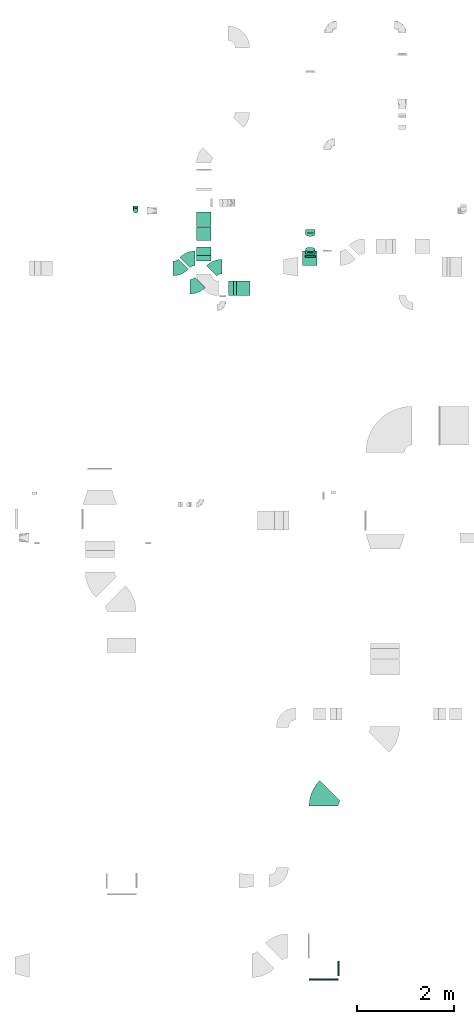
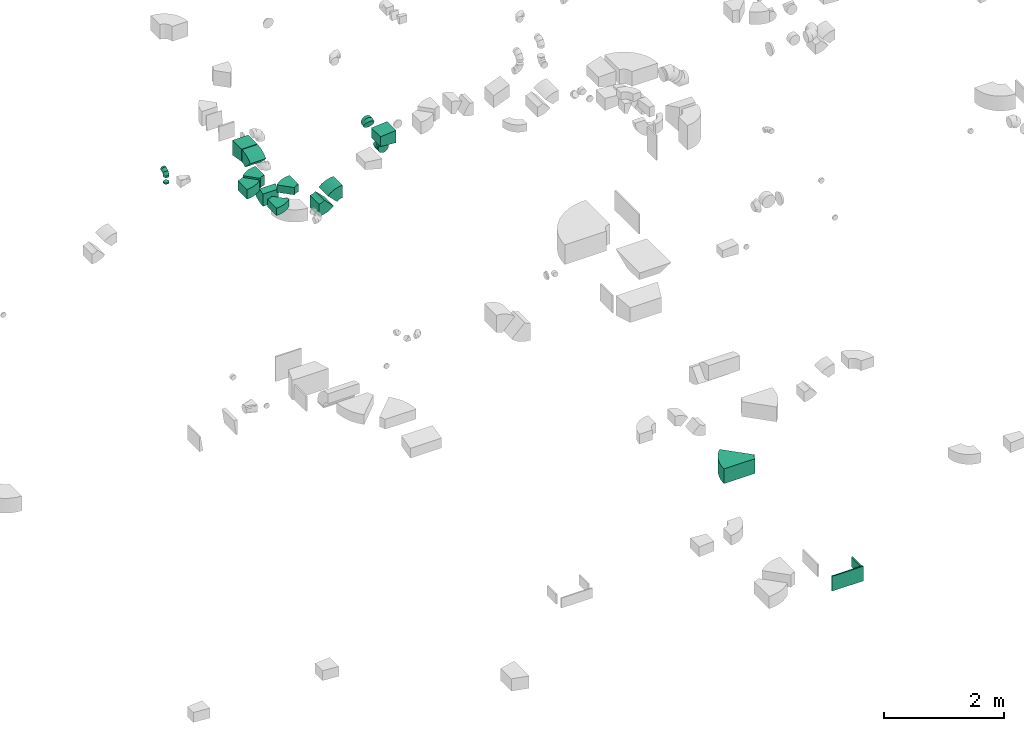
# One storey, part 23 of 44: 18 flow fittings.
"""IFC2X3 building model written with IfcOpenShell, lengths in millimetres."""

from ifc_helpers import new_model, entity, si_unit, converted_unit, derived_unit, direction, frame, frame_2d, origin, origin_2d_with_axis, place, context, subcontext, project, spatial, polyline, circle_curve, parameter, trimmed, segment, composite_curve, rectangle, outline, extrude, faceted_brep, source, transform, mapped, material, type_object, type_shapes, element, save


model = new_model("IFC2X3")

# Units and contexts
model_context = context("Model", 3, precision=0.01, world=origin(), true_north=direction((6.12303176911189e-17, 1.0)))
body_context = subcontext(model_context, "Body", "Model", "MODEL_VIEW")
ifc_project = project(units=[si_unit("LENGTHUNIT", "METRE", prefix="MILLI"), si_unit("AREAUNIT", "SQUARE_METRE"), si_unit("VOLUMEUNIT", "CUBIC_METRE"), converted_unit("PLANEANGLEUNIT", "DEGREE", entity("IfcRatioMeasure", 0.0174532925199433), si_unit("PLANEANGLEUNIT", "RADIAN"), dimensions=[0, 0, 0, 0, 0, 0, 0]), si_unit("MASSUNIT", "GRAM", prefix="KILO"), derived_unit("MASSDENSITYUNIT", [(si_unit("MASSUNIT", "GRAM", prefix="KILO"), 1), (si_unit("LENGTHUNIT", "METRE"), -3)]), derived_unit("MOMENTOFINERTIAUNIT", [(si_unit("LENGTHUNIT", "METRE"), 4)]), si_unit("TIMEUNIT", "SECOND"), si_unit("FREQUENCYUNIT", "HERTZ"), si_unit("THERMODYNAMICTEMPERATUREUNIT", "DEGREE_CELSIUS"), derived_unit("THERMALTRANSMITTANCEUNIT", [(si_unit("MASSUNIT", "GRAM", prefix="KILO"), 1), (si_unit("THERMODYNAMICTEMPERATUREUNIT", "KELVIN"), -1), (si_unit("TIMEUNIT", "SECOND"), -3)]), derived_unit("VOLUMETRICFLOWRATEUNIT", [(si_unit("LENGTHUNIT", "METRE"), 3), (si_unit("TIMEUNIT", "SECOND"), -1)]), derived_unit("MASSFLOWRATEUNIT", [(si_unit("MASSUNIT", "GRAM", prefix="KILO"), 1), (si_unit("TIMEUNIT", "SECOND"), -1)]), derived_unit("ROTATIONALFREQUENCYUNIT", [(si_unit("TIMEUNIT", "SECOND"), -1)]), si_unit("ELECTRICCURRENTUNIT", "AMPERE"), si_unit("ELECTRICVOLTAGEUNIT", "VOLT"), si_unit("POWERUNIT", "WATT"), si_unit("FORCEUNIT", "NEWTON", prefix="KILO"), si_unit("ILLUMINANCEUNIT", "LUX"), si_unit("LUMINOUSFLUXUNIT", "LUMEN"), si_unit("LUMINOUSINTENSITYUNIT", "CANDELA"), derived_unit("USERDEFINED", [(si_unit("MASSUNIT", "GRAM", prefix="KILO"), -1), (si_unit("LENGTHUNIT", "METRE"), -2), (si_unit("TIMEUNIT", "SECOND"), 3), (si_unit("LUMINOUSFLUXUNIT", "LUMEN"), 1)]), derived_unit("LINEARVELOCITYUNIT", [(si_unit("LENGTHUNIT", "METRE"), 1), (si_unit("TIMEUNIT", "SECOND"), -1)]), si_unit("PRESSUREUNIT", "PASCAL"), derived_unit("USERDEFINED", [(si_unit("LENGTHUNIT", "METRE"), -2), (si_unit("MASSUNIT", "GRAM", prefix="KILO"), 1), (si_unit("TIMEUNIT", "SECOND"), -2)]), derived_unit("LINEARFORCEUNIT", [(si_unit("MASSUNIT", "GRAM", prefix="KILO"), 1), (si_unit("LENGTHUNIT", "METRE"), 1), (si_unit("TIMEUNIT", "SECOND"), -2), (si_unit("LENGTHUNIT", "METRE"), -1)]), derived_unit("PLANARFORCEUNIT", [(si_unit("MASSUNIT", "GRAM", prefix="KILO"), 1), (si_unit("LENGTHUNIT", "METRE"), 1), (si_unit("TIMEUNIT", "SECOND"), -2), (si_unit("LENGTHUNIT", "METRE"), -2)])], contexts=[model_context])

# Site, building, storey
site_placement = place(None, origin())
site = spatial("IfcSite", under=ifc_project, at=site_placement, CompositionType="ELEMENT")
building_placement = place(site_placement, origin())
building = spatial("IfcBuilding", under=site, at=building_placement, CompositionType="ELEMENT")
storey_placement = place(building_placement, frame((0.0, 0.0, 15900.0)))
storey = spatial("IfcBuildingStorey", under=building, at=storey_placement, CompositionType="ELEMENT", Elevation=15900.0)

# Flow fittings
ifc_material = material()
duct_fitting_type_1 = type_object("IfcDuctFittingType", PredefinedType="NOTDEFINED", material=ifc_material)
shared_shape_1 = source(origin(), body_context, "Body", "SweptSolid", [
    extrude(rectangle(XDim=300.0, YDim=26.096, at=origin_2d_with_axis()), frame((6.95, 0.0, -100.0), z_axis=(0.0, 0.0, 1.0), x_axis=(0.0, -1.0, 0.0)), (0.0, 0.0, 1.0), 200.0),
])
type_shapes(duct_fitting_type_1, [shared_shape_1])
flow_fitting_1_placement = place(storey_placement, frame((49547.23, 463.31, 3275.0), z_axis=(0.0, 0.0, -1.0), x_axis=(1.0, 0.0, 0.0)))
element("IfcFlowFitting", 1, at=flow_fitting_1_placement, inside=storey, type_object=duct_fitting_type_1, material=ifc_material, context=body_context, shape_type="MappedRepresentation", body=[
    mapped(shared_shape_1, transform((0.0, 0.0, 0.0), scale=1.0)),
])
duct_fitting_type_2 = type_object("IfcDuctFittingType", PredefinedType="NOTDEFINED", material=ifc_material)
shared_shape_2 = source(origin(), body_context, "Body", "SweptSolid", [
    extrude(rectangle(XDim=24.9999999999999, YDim=600.0, at=origin_2d_with_axis()), frame((12.5, 0.0, -150.0)), (0.0, 0.0, 1.0), 300.0),
])
type_shapes(duct_fitting_type_2, [shared_shape_2])
flow_fitting_2_placement = place(storey_placement, frame((49247.23, 249.41, 3275.0), z_axis=(0.0, 0.0, 1.0), x_axis=(0.0, -1.0, 0.0)))
element("IfcFlowFitting", 2, at=flow_fitting_2_placement, inside=storey, type_object=duct_fitting_type_2, material=ifc_material, context=body_context, shape_type="MappedRepresentation", body=[
    mapped(shared_shape_2, transform((0.0, 0.0, 0.0), scale=1.0)),
])
duct_fitting_type_3 = type_object("IfcDuctFittingType", PredefinedType="NOTDEFINED", material=ifc_material)
shared_shape_3 = source(origin(), body_context, "Body", "SweptSolid", [
    extrude(outline(polyline([(-159.86, -112.11), (141.18, -112.11), (157.79, 87.2), (-139.1, 137.03), (-159.86, -112.11)])), frame((150.0, -150.0, 0.0), z_axis=(0.0, 1.0, 0.0), x_axis=(0.996545758244872, 0.0, -0.0830454798538357)), (0.0, 0.0, 1.0), 300.0),
])
type_shapes(duct_fitting_type_3, [shared_shape_3])
flow_fitting_3_placement = place(storey_placement, frame((49113.9, 15148.63, 3325.02), z_axis=(0.0, 0.0, 1.0), x_axis=(-1.0, 0.0, 0.0)))
element("IfcFlowFitting", 3, at=flow_fitting_3_placement, inside=storey, type_object=duct_fitting_type_3, material=ifc_material, context=body_context, shape_type="MappedRepresentation", body=[
    mapped(shared_shape_3, transform((0.0, 0.0, 0.0), scale=1.0)),
])
duct_fitting_type_4 = type_object("IfcDuctFittingType", PredefinedType="NOTDEFINED", material=ifc_material)
shared_shape_4 = source(origin(), body_context, "Body", "SweptSolid", [
    extrude(outline(polyline([(-150.0, -137.5), (150.0, -137.5), (150.0, 112.5), (-150.0, 162.5), (-150.0, -137.5)])), frame((150.0, -150.0, 12.5), z_axis=(0.0, 1.0, 0.0), x_axis=(1.0, 0.0, 0.0)), (0.0, 0.0, 1.0), 300.0),
])
type_shapes(duct_fitting_type_4, [shared_shape_4])
flow_fitting_4_placement = place(storey_placement, frame((46769.03, 16110.23, 3300.0), z_axis=(0.0, 0.0, 1.0), x_axis=(0.0, -1.0, 0.0)))
element("IfcFlowFitting", 4, at=flow_fitting_4_placement, inside=storey, type_object=duct_fitting_type_4, material=ifc_material, context=body_context, shape_type="MappedRepresentation", body=[
    mapped(shared_shape_4, transform((0.0, 0.0, 0.0), scale=1.0)),
])
duct_fitting_type_5 = type_object("IfcDuctFittingType", PredefinedType="NOTDEFINED", material=ifc_material)
shared_shape_5 = source(origin(), body_context, "Body", "Brep", [
    faceted_brep([(-100.0, 0.0, -50.0), (-100.0, -12.94, -48.3), (-100.0, -25.0, -43.3), (-100.0, -35.36, -35.36), (-100.0, -43.3, -25.0), (-100.0, -48.3, -12.94), (-100.0, -50.0, 0.0), (-100.0, -48.3, 12.94), (-100.0, -43.3, 25.0), (-100.0, -35.36, 35.36), (-100.0, -25.0, 43.3), (-100.0, -12.94, 48.3), (-100.0, 0.0, 50.0), (-100.0, 12.94, 48.3), (-100.0, 25.0, 43.3), (-100.0, 35.36, 35.36), (-100.0, 43.3, 25.0), (-100.0, 48.3, 12.94), (-100.0, 50.0, 0.0), (-100.0, 48.3, -12.94), (-100.0, 43.3, -25.0), (-100.0, 35.36, -35.36), (-100.0, 25.0, -43.3), (-100.0, 12.94, -48.3), (-76.67, 12.94, 48.3), (-79.9, 25.0, 43.3), (-73.21, 0.0, 50.0), (-82.68, 35.36, 35.36), (-86.15, 48.3, 12.94), (-86.6, 50.0, 0.0), (-84.81, 43.3, 25.0), (-84.81, 43.3, -25.0), (-82.68, 35.36, -35.36), (-86.15, 48.3, -12.94), (-76.67, 12.94, -48.3), (-73.21, 0.0, -50.0), (-79.9, 25.0, -43.3), (-69.74, -12.94, -48.3), (-66.51, -25.0, -43.3), (-63.73, -35.36, -35.36), (-61.6, -43.3, -25.0), (-60.26, -48.3, -12.94), (-59.81, -50.0, 0.0), (-60.26, -48.3, 12.94), (-61.6, -43.3, 25.0), (-63.73, -35.36, 35.36), (-66.51, -25.0, 43.3), (-69.74, -12.94, 48.3), (-36.27, 36.27, 48.3), (-45.1, 45.1, 43.3), (-26.79, 26.79, 50.0), (-52.68, 52.68, 35.36), (-58.49, 58.49, 25.0), (-62.15, 62.15, 12.94), (-63.4, 63.4, 0.0), (-62.15, 62.15, -12.94), (-58.49, 58.49, -25.0), (-52.68, 52.68, -35.36), (-36.27, 36.27, -48.3), (-26.79, 26.79, -50.0), (-45.1, 45.1, -43.3), (-17.32, 17.32, -48.3), (-8.49, 8.49, -43.3), (-0.91, 0.91, -35.36), (4.9, -4.9, -25.0), (8.56, -8.56, -12.94), (9.81, -9.81, 0.0), (8.56, -8.56, 12.94), (4.9, -4.9, 25.0), (-0.91, 0.91, 35.36), (-8.49, 8.49, 43.3), (-17.32, 17.32, 48.3), (-12.94, 76.67, 48.3), (-25.0, 79.9, 43.3), (0.0, 73.21, 50.0), (-35.36, 82.68, 35.36), (-43.3, 84.81, 25.0), (-48.3, 86.15, 12.94), (-50.0, 86.6, 0.0), (-48.3, 86.15, -12.94), (-43.3, 84.81, -25.0), (-35.36, 82.68, -35.36), (-12.94, 76.67, -48.3), (0.0, 73.21, -50.0), (-25.0, 79.9, -43.3), (12.94, 69.74, -48.3), (25.0, 66.51, -43.3), (35.36, 63.73, -35.36), (43.3, 61.6, -25.0), (48.3, 60.26, -12.94), (50.0, 59.81, 0.0), (48.3, 60.26, 12.94), (43.3, 61.6, 25.0), (35.36, 63.73, 35.36), (25.0, 66.51, 43.3), (12.94, 69.74, 48.3), (-12.94, 100.0, -48.3), (-25.0, 100.0, -43.3), (-35.36, 100.0, -35.36), (-43.3, 100.0, -25.0), (-48.3, 100.0, -12.94), (-50.0, 100.0, 0.0), (-48.3, 100.0, 12.94), (-43.3, 100.0, 25.0), (-35.36, 100.0, 35.36), (-25.0, 100.0, 43.3), (-12.94, 100.0, 48.3), (0.0, 100.0, 50.0), (12.94, 100.0, 48.3), (25.0, 100.0, 43.3), (35.36, 100.0, 35.36), (43.3, 100.0, 25.0), (48.3, 100.0, 12.94), (50.0, 100.0, 0.0), (48.3, 100.0, -12.94), (43.3, 100.0, -25.0), (35.36, 100.0, -35.36), (25.0, 100.0, -43.3), (12.94, 100.0, -48.3), (0.0, 100.0, -50.0)], [[[0, 1, 2, 3, 4, 5, 6, 7, 8, 9, 10, 11, 12, 13, 14, 15, 16, 17, 18, 19, 20, 21, 22, 23]], [[24, 25, 14, 13]], [[26, 24, 13, 12]], [[14, 25, 27, 15]], [[28, 29, 18, 17]], [[30, 28, 17, 16]], [[15, 27, 30, 16]], [[20, 31, 32, 21]], [[33, 31, 20, 19]], [[18, 29, 33, 19]], [[34, 35, 0, 23]], [[36, 34, 23, 22]], [[32, 36, 22, 21]], [[2, 1, 37, 38]], [[3, 2, 38, 39]], [[0, 35, 37, 1]], [[5, 4, 40, 41]], [[6, 5, 41, 42]], [[3, 39, 40, 4]], [[6, 42, 43, 7]], [[7, 43, 44, 8]], [[8, 44, 45, 9]], [[10, 46, 47, 11]], [[11, 47, 26, 12]], [[10, 9, 45, 46]], [[48, 49, 25, 24]], [[50, 48, 24, 26]], [[27, 25, 49, 51]], [[52, 53, 28, 30]], [[51, 52, 30, 27]], [[29, 28, 53, 54]], [[55, 56, 31, 33]], [[54, 55, 33, 29]], [[57, 32, 31, 56]], [[58, 59, 35, 34]], [[60, 58, 34, 36]], [[57, 60, 36, 32]], [[37, 35, 59, 61]], [[38, 37, 61, 62]], [[39, 38, 62, 63]], [[41, 40, 64, 65]], [[42, 41, 65, 66]], [[63, 64, 40, 39]], [[43, 42, 66, 67]], [[44, 43, 67, 68]], [[68, 69, 45, 44]], [[46, 45, 69, 70]], [[47, 46, 70, 71]], [[26, 47, 71, 50]], [[72, 73, 49, 48]], [[74, 72, 48, 50]], [[51, 49, 73, 75]], [[76, 77, 53, 52]], [[75, 76, 52, 51]], [[54, 53, 77, 78]], [[79, 80, 56, 55]], [[78, 79, 55, 54]], [[81, 57, 56, 80]], [[82, 83, 59, 58]], [[84, 82, 58, 60]], [[81, 84, 60, 57]], [[61, 59, 83, 85]], [[62, 61, 85, 86]], [[63, 62, 86, 87]], [[65, 64, 88, 89]], [[66, 65, 89, 90]], [[87, 88, 64, 63]], [[67, 66, 90, 91]], [[68, 67, 91, 92]], [[92, 93, 69, 68]], [[70, 69, 93, 94]], [[71, 70, 94, 95]], [[50, 71, 95, 74]], [[96, 97, 98, 99, 100, 101, 102, 103, 104, 105, 106, 107, 108, 109, 110, 111, 112, 113, 114, 115, 116, 117, 118, 119]], [[72, 74, 107, 106]], [[73, 72, 106, 105]], [[75, 73, 105, 104]], [[77, 76, 103, 102]], [[78, 77, 102, 101]], [[75, 104, 103, 76]], [[78, 101, 100, 79]], [[79, 100, 99, 80]], [[80, 99, 98, 81]], [[96, 119, 83, 82]], [[97, 96, 82, 84]], [[84, 81, 98, 97]], [[83, 119, 118, 85]], [[85, 118, 117, 86]], [[86, 117, 116, 87]], [[88, 115, 114, 89]], [[89, 114, 113, 90]], [[87, 116, 115, 88]], [[91, 90, 113, 112]], [[92, 91, 112, 111]], [[93, 92, 111, 110]], [[95, 94, 109, 108]], [[74, 95, 108, 107]], [[110, 109, 94, 93]]]),
])
type_shapes(duct_fitting_type_5, [shared_shape_5])
flow_fitting_5_placement = place(storey_placement, frame((45360.34, 16131.51, 3250.0), z_axis=(1.0, 0.0, 0.0), x_axis=(0.0, -1.0, 0.0)))
element("IfcFlowFitting", 5, at=flow_fitting_5_placement, inside=storey, type_object=duct_fitting_type_5, material=ifc_material, context=body_context, shape_type="MappedRepresentation", body=[
    mapped(shared_shape_5, transform((0.0, 0.0, 0.0), scale=1.0)),
])
duct_fitting_type_6 = type_object("IfcDuctFittingType", PredefinedType="NOTDEFINED", material=ifc_material)
shared_shape_6 = source(origin(), body_context, "Body", "Brep", [
    faceted_brep([(20.0, 25.88, -96.59), (20.0, 50.0, -86.6), (20.0, 70.71, -70.71), (20.0, 86.6, -50.0), (20.0, 96.59, -25.88), (20.0, 100.0, 0.0), (20.0, 96.59, 25.88), (20.0, 86.6, 50.0), (20.0, 70.71, 70.71), (20.0, 50.0, 86.6), (20.0, 25.88, 96.59), (20.0, 0.0, 100.0), (20.0, -25.88, 96.59), (20.0, -50.0, 86.6), (20.0, -70.71, 70.71), (20.0, -86.6, 50.0), (20.0, -96.59, 25.88), (20.0, -100.0, 0.0), (20.0, -96.59, -25.88), (20.0, -86.6, -50.0), (20.0, -70.71, -70.71), (20.0, -50.0, -86.6), (20.0, -25.88, -96.59), (20.0, 0.0, -100.0), (0.0, 0.0, 100.0), (0.0, 25.88, 96.59), (-6.1, 25.88, 96.59), (-6.1, 0.0, 100.0), (0.0, 50.0, 86.6), (-6.1, 50.0, 86.6), (0.0, 70.71, 70.71), (-6.1, 70.71, 70.71), (0.0, 86.6, 50.0), (0.0, 96.59, 25.88), (-6.1, 96.59, 25.88), (-6.1, 86.6, 50.0), (0.0, 100.0, 0.0), (-6.1, 100.0, 0.0), (0.0, 96.59, -25.88), (-6.1, 96.59, -25.88), (0.0, 86.6, -50.0), (-6.1, 86.6, -50.0), (0.0, 70.71, -70.71), (-6.1, 70.71, -70.71), (0.0, 50.0, -86.6), (0.0, 25.88, -96.59), (-6.1, 25.88, -96.59), (-6.1, 50.0, -86.6), (0.0, 0.0, -100.0), (-6.1, 0.0, -100.0), (0.0, -25.88, -96.59), (-6.1, -25.88, -96.59), (0.0, -50.0, -86.6), (-6.1, -50.0, -86.6), (0.0, -70.71, -70.71), (-6.1, -70.71, -70.71), (0.0, -86.6, -50.0), (0.0, -96.59, -25.88), (-6.1, -96.59, -25.88), (-6.1, -86.6, -50.0), (0.0, -100.0, 0.0), (-6.1, -100.0, 0.0), (0.0, -96.59, 25.88), (-6.1, -96.59, 25.88), (0.0, -86.6, 50.0), (-6.1, -86.6, 50.0), (0.0, -70.71, 70.71), (-6.1, -70.71, 70.71), (0.0, -50.0, 86.6), (0.0, -25.88, 96.59), (-6.1, -25.88, 96.59), (-6.1, -50.0, 86.6)], [[[0, 1, 2, 3, 4, 5, 6, 7, 8, 9, 10, 11, 12, 13, 14, 15, 16, 17, 18, 19, 20, 21, 22, 23]], [[24, 11, 10, 25, 26, 27]], [[25, 10, 9, 28, 29, 26]], [[28, 9, 8, 30, 31, 29]], [[32, 7, 6, 33, 34, 35]], [[33, 6, 5, 36, 37, 34]], [[30, 8, 7, 32, 35, 31]], [[36, 5, 4, 38, 39, 37]], [[38, 4, 3, 40, 41, 39]], [[40, 3, 2, 42, 43, 41]], [[44, 1, 0, 45, 46, 47]], [[45, 0, 23, 48, 49, 46]], [[42, 2, 1, 44, 47, 43]], [[48, 23, 22, 50, 51, 49]], [[50, 22, 21, 52, 53, 51]], [[52, 21, 20, 54, 55, 53]], [[56, 19, 18, 57, 58, 59]], [[57, 18, 17, 60, 61, 58]], [[54, 20, 19, 56, 59, 55]], [[60, 17, 16, 62, 63, 61]], [[62, 16, 15, 64, 65, 63]], [[64, 15, 14, 66, 67, 65]], [[68, 13, 12, 69, 70, 71]], [[69, 12, 11, 24, 27, 70]], [[66, 14, 13, 68, 71, 67]], [[49, 51, 53, 55, 59, 58, 61, 63, 65, 67, 71, 70, 27, 26, 29, 31, 35, 34, 37, 39, 41, 43, 47, 46]]]),
])
type_shapes(duct_fitting_type_6, [shared_shape_6])
flow_fitting_6_placement = place(storey_placement, frame((48969.75, 15175.52, 3050.0), z_axis=(0.0, 0.0, -1.0), x_axis=(0.0, 1.0, 0.0)))
element("IfcFlowFitting", 6, at=flow_fitting_6_placement, inside=storey, type_object=duct_fitting_type_6, material=ifc_material, context=body_context, shape_type="MappedRepresentation", body=[
    mapped(shared_shape_6, transform((0.0, 0.0, 0.0), scale=1.0)),
])
duct_fitting_type_7 = type_object("IfcDuctFittingType", PredefinedType="NOTDEFINED", material=ifc_material)
shared_shape_7 = source(origin(), body_context, "Body", "Brep", [
    faceted_brep([(20.0, 12.94, -48.3), (20.0, 25.0, -43.3), (20.0, 35.36, -35.36), (20.0, 43.3, -25.0), (20.0, 48.3, -12.94), (20.0, 50.0, 0.0), (20.0, 48.3, 12.94), (20.0, 43.3, 25.0), (20.0, 35.36, 35.36), (20.0, 25.0, 43.3), (20.0, 12.94, 48.3), (20.0, 0.0, 50.0), (20.0, -12.94, 48.3), (20.0, -25.0, 43.3), (20.0, -35.36, 35.36), (20.0, -43.3, 25.0), (20.0, -48.3, 12.94), (20.0, -50.0, 0.0), (20.0, -48.3, -12.94), (20.0, -43.3, -25.0), (20.0, -35.36, -35.36), (20.0, -25.0, -43.3), (20.0, -12.94, -48.3), (20.0, 0.0, -50.0), (0.0, 0.0, 50.0), (0.0, 12.94, 48.3), (-6.1, 12.94, 48.3), (-6.1, 0.0, 50.0), (0.0, 25.0, 43.3), (-6.1, 25.0, 43.3), (0.0, 35.36, 35.36), (-6.1, 35.36, 35.36), (0.0, 43.3, 25.0), (0.0, 48.3, 12.94), (-6.1, 48.3, 12.94), (-6.1, 43.3, 25.0), (0.0, 50.0, 0.0), (-6.1, 50.0, 0.0), (0.0, 48.3, -12.94), (-6.1, 48.3, -12.94), (0.0, 43.3, -25.0), (-6.1, 43.3, -25.0), (0.0, 35.36, -35.36), (-6.1, 35.36, -35.36), (0.0, 25.0, -43.3), (0.0, 12.94, -48.3), (-6.1, 12.94, -48.3), (-6.1, 25.0, -43.3), (0.0, 0.0, -50.0), (-6.1, 0.0, -50.0), (0.0, -12.94, -48.3), (-6.1, -12.94, -48.3), (0.0, -25.0, -43.3), (-6.1, -25.0, -43.3), (0.0, -35.36, -35.36), (-6.1, -35.36, -35.36), (0.0, -43.3, -25.0), (0.0, -48.3, -12.94), (-6.1, -48.3, -12.94), (-6.1, -43.3, -25.0), (0.0, -50.0, 0.0), (-6.1, -50.0, 0.0), (0.0, -48.3, 12.94), (-6.1, -48.3, 12.94), (0.0, -43.3, 25.0), (-6.1, -43.3, 25.0), (0.0, -35.36, 35.36), (-6.1, -35.36, 35.36), (0.0, -25.0, 43.3), (0.0, -12.94, 48.3), (-6.1, -12.94, 48.3), (-6.1, -25.0, 43.3)], [[[0, 1, 2, 3, 4, 5, 6, 7, 8, 9, 10, 11, 12, 13, 14, 15, 16, 17, 18, 19, 20, 21, 22, 23]], [[24, 11, 10, 25, 26, 27]], [[25, 10, 9, 28, 29, 26]], [[28, 9, 8, 30, 31, 29]], [[32, 7, 6, 33, 34, 35]], [[33, 6, 5, 36, 37, 34]], [[30, 8, 7, 32, 35, 31]], [[36, 5, 4, 38, 39, 37]], [[38, 4, 3, 40, 41, 39]], [[40, 3, 2, 42, 43, 41]], [[44, 1, 0, 45, 46, 47]], [[45, 0, 23, 48, 49, 46]], [[42, 2, 1, 44, 47, 43]], [[48, 23, 22, 50, 51, 49]], [[50, 22, 21, 52, 53, 51]], [[52, 21, 20, 54, 55, 53]], [[56, 19, 18, 57, 58, 59]], [[57, 18, 17, 60, 61, 58]], [[54, 20, 19, 56, 59, 55]], [[60, 17, 16, 62, 63, 61]], [[62, 16, 15, 64, 65, 63]], [[64, 15, 14, 66, 67, 65]], [[68, 13, 12, 69, 70, 71]], [[69, 12, 11, 24, 27, 70]], [[66, 14, 13, 68, 71, 67]], [[49, 51, 53, 55, 59, 58, 61, 63, 65, 67, 71, 70, 27, 26, 29, 31, 35, 34, 37, 39, 41, 43, 47, 46]]]),
])
type_shapes(duct_fitting_type_7, [shared_shape_7])
flow_fitting_7_placement = place(storey_placement, frame((45360.34, 16131.51, 3025.0), z_axis=(0.0, -1.0, 0.0), x_axis=(0.0, 0.0, 1.0)))
element("IfcFlowFitting", 7, at=flow_fitting_7_placement, inside=storey, type_object=duct_fitting_type_7, material=ifc_material, context=body_context, shape_type="MappedRepresentation", body=[
    mapped(shared_shape_7, transform((0.0, 0.0, 0.0), scale=1.0)),
])
duct_fitting_type_8 = type_object("IfcDuctFittingType", PredefinedType="NOTDEFINED", material=ifc_material)
shared_shape_8 = source(origin(), body_context, "Body", "Brep", [
    faceted_brep([(-48.02, 0.0, -100.0), (-48.02, -25.88, -96.59), (-48.02, -50.0, -86.6), (-48.02, -70.71, -70.71), (-48.02, -86.6, -50.0), (-48.02, -96.59, -25.88), (-48.02, -100.0, 0.0), (-48.02, -96.59, 25.88), (-48.02, -86.6, 50.0), (-48.02, -70.71, 70.71), (-48.02, -50.0, 86.6), (-48.02, -25.88, 96.59), (-48.02, 0.0, 100.0), (-48.02, 25.88, 96.59), (-48.02, 50.0, 86.6), (-48.02, 70.71, 70.71), (-48.02, 86.6, 50.0), (-48.02, 96.59, 25.88), (-48.02, 100.0, 0.0), (-48.02, 96.59, -25.88), (-48.02, 86.6, -50.0), (-48.02, 70.71, -70.71), (-48.02, 50.0, -86.6), (-48.02, 25.88, -96.59), (-6.21, 25.88, 96.59), (-12.0, 50.0, 86.6), (0.0, 0.0, 100.0), (-16.98, 70.71, 70.71), (-23.19, 96.59, 25.88), (-24.01, 100.0, 0.0), (-20.79, 86.6, 50.0), (-20.79, 86.6, -50.0), (-16.98, 70.71, -70.71), (-23.19, 96.59, -25.88), (-6.21, 25.88, -96.59), (0.0, 0.0, -100.0), (-12.0, 50.0, -86.6), (6.21, -25.88, -96.59), (12.0, -50.0, -86.6), (16.98, -70.71, -70.71), (20.79, -86.6, -50.0), (23.19, -96.59, -25.88), (24.01, -100.0, 0.0), (23.19, -96.59, 25.88), (20.79, -86.6, 50.0), (16.98, -70.71, 70.71), (12.0, -50.0, 86.6), (6.21, -25.88, 96.59), (42.78, 21.8, 100.0), (31.03, 44.86, 96.59), (20.08, 66.35, 86.6), (10.68, 84.8, 70.71), (3.47, 98.96, 50.0), (-1.07, 107.86, 25.88), (-2.62, 110.9, 0.0), (-1.07, 107.86, -25.88), (3.47, 98.96, -50.0), (10.68, 84.8, -70.71), (20.08, 66.35, -86.6), (31.03, 44.86, -96.59), (42.78, 21.8, -100.0), (54.53, -1.26, -96.59), (65.48, -22.75, -86.6), (74.88, -41.2, -70.71), (82.1, -55.36, -50.0), (86.63, -64.27, -25.88), (88.18, -67.3, 0.0), (86.63, -64.27, 25.88), (82.1, -55.36, 50.0), (74.88, -41.2, 70.71), (65.48, -22.75, 86.6), (54.53, -1.26, 96.59)], [[[0, 1, 2, 3, 4, 5, 6, 7, 8, 9, 10, 11, 12, 13, 14, 15, 16, 17, 18, 19, 20, 21, 22, 23]], [[24, 25, 14, 13]], [[26, 24, 13, 12]], [[14, 25, 27, 15]], [[28, 29, 18, 17]], [[30, 28, 17, 16]], [[15, 27, 30, 16]], [[20, 31, 32, 21]], [[33, 31, 20, 19]], [[18, 29, 33, 19]], [[34, 35, 0, 23]], [[36, 34, 23, 22]], [[32, 36, 22, 21]], [[1, 0, 35, 37]], [[2, 1, 37, 38]], [[3, 2, 38, 39]], [[5, 4, 40, 41]], [[6, 5, 41, 42]], [[39, 40, 4, 3]], [[6, 42, 43, 7]], [[7, 43, 44, 8]], [[8, 44, 45, 9]], [[9, 45, 46, 10]], [[10, 46, 47, 11]], [[26, 12, 11, 47]], [[24, 26, 48, 49]], [[25, 24, 49, 50]], [[27, 25, 50, 51]], [[28, 30, 52, 53]], [[29, 28, 53, 54]], [[27, 51, 52, 30]], [[29, 54, 55, 33]], [[33, 55, 56, 31]], [[31, 56, 57, 32]], [[36, 58, 59, 34]], [[34, 59, 60, 35]], [[36, 32, 57, 58]], [[61, 62, 38, 37]], [[60, 61, 37, 35]], [[63, 39, 38, 62]], [[40, 64, 65, 41]], [[41, 65, 66, 42]], [[64, 40, 39, 63]], [[67, 68, 44, 43]], [[66, 67, 43, 42]], [[68, 69, 45, 44]], [[47, 46, 70, 71]], [[26, 47, 71, 48]], [[69, 70, 46, 45]], [[59, 58, 57, 56, 55, 54, 53, 52, 51, 50, 49, 48, 71, 70, 69, 68, 67, 66, 65, 64, 63, 62, 61, 60]]]),
])
type_shapes(duct_fitting_type_8, [shared_shape_8])
for number, where, z_axis, x_axis in (
    (8, (48969.75, 15690.52, 3255.0), (1.0, 0.0, 0.0), (0.0, -1.0, 0.0)),
    (9, (48969.75, 15288.18, 3050.0), (-1.0, 0.0, 0.0), (0.0, -0.891006524188343, -0.453990499739595)),
):
    element("IfcFlowFitting", number, at=place(storey_placement, frame(where, z_axis=z_axis, x_axis=x_axis)), inside=storey, type_object=duct_fitting_type_8, material=ifc_material, context=body_context, shape_type="MappedRepresentation", body=[
        mapped(shared_shape_8, transform((0.0, 0.0, 0.0), scale=1.0)),
    ])
duct_fitting_type_9 = type_object("IfcDuctFittingType", PredefinedType="NOTDEFINED", material=ifc_material)
shared_shape_9 = source(origin(), body_context, "Body", "SweptSolid", [
    extrude(outline(composite_curve([segment(polyline([(-365.9, -159.1), (234.1, -159.1)]), True, "CONTINUOUS"), segment(trimmed(circle_curve(frame_2d((384.1, -159.1), x_axis=(-0.707106781186553, 0.707106781186546)), 150.0), [parameter(0.0)], [parameter(45.0)], True, "PARAMETER"), False, "CONTINUOUS"), segment(polyline([(278.03, -53.03), (-146.23, 371.23)]), True, "CONTINUOUS"), segment(trimmed(circle_curve(frame_2d((384.1, -159.1), x_axis=(-0.707106781186553, 0.707106781186546)), 750.0), [parameter(0.0)], [parameter(45.0)], True, "PARAMETER"), True, "CONTINUOUS")], self_intersect=False)), frame((-27.3, 65.9, -150.0), z_axis=(0.0, 0.0, 1.0), x_axis=(-0.707106781186547, 0.707106781186548, 0.0)), (0.0, 0.0, 1.0), 300.0),
])
type_shapes(duct_fitting_type_9, [shared_shape_9])
flow_fitting_8_placement = place(storey_placement, frame((49247.23, 4004.41, 3275.0), z_axis=(0.0, 0.0, 1.0), x_axis=(-0.707106781186553, -0.707106781186543, 0.0)))
element("IfcFlowFitting", 10, at=flow_fitting_8_placement, inside=storey, type_object=duct_fitting_type_9, material=ifc_material, context=body_context, shape_type="MappedRepresentation", body=[
    mapped(shared_shape_9, transform((0.0, 0.0, 0.0), scale=1.0)),
])
duct_fitting_type_10 = type_object("IfcDuctFittingType", PredefinedType="NOTDEFINED", material=ifc_material)
shared_shape_10 = source(origin(), body_context, "Body", "SweptSolid", [
    extrude(outline(composite_curve([segment(polyline([(-165.27, -97.23), (84.73, -97.23)]), True, "CONTINUOUS"), segment(trimmed(circle_curve(frame_2d((234.73, -97.23), x_axis=(-0.707106781186546, 0.707106781186546)), 150.0), [parameter(0.0)], [parameter(45.0)], True, "PARAMETER"), False, "CONTINUOUS"), segment(polyline([(128.66, 8.84), (-48.12, 185.62)]), True, "CONTINUOUS"), segment(trimmed(circle_curve(frame_2d((234.73, -97.23), x_axis=(-0.707106781186546, 0.707106781186546)), 400.0), [parameter(0.0)], [parameter(45.0)], True, "PARAMETER"), True, "CONTINUOUS")], self_intersect=False)), frame((-16.68, 40.27, -150.0), z_axis=(0.0, 0.0, 1.0), x_axis=(-0.707106781186547, 0.707106781186548, 0.0)), (0.0, 0.0, 1.0), 300.0),
])
type_shapes(duct_fitting_type_10, [shared_shape_10])
for number, where, z_axis, x_axis in (
    (11, (46769.03, 15685.23, 3325.0), (1.0, 0.0, 0.0), (0.0, -1.0, 0.0)),
    (12, (46769.03, 15210.23, 2850.0), (-1.0, 0.0, 0.0), (0.0, -0.707106781186548, -0.707106781186548)),
):
    element("IfcFlowFitting", number, at=place(storey_placement, frame(where, z_axis=z_axis, x_axis=x_axis)), inside=storey, type_object=duct_fitting_type_10, material=ifc_material, context=body_context, shape_type="MappedRepresentation", body=[
        mapped(shared_shape_10, transform((0.0, 0.0, 0.0), scale=1.0)),
    ])
duct_fitting_type_11 = type_object("IfcDuctFittingType", PredefinedType="NOTDEFINED", material=ifc_material)
shared_shape_11 = source(origin(), body_context, "Body", "SweptSolid", [
    extrude(outline(composite_curve([segment(polyline([(-165.27, -97.23), (84.73, -97.23)]), True, "CONTINUOUS"), segment(trimmed(circle_curve(frame_2d((234.73, -97.23), x_axis=(-0.707106792500269, 0.70710676987283)), 150.0), [parameter(0.0)], [parameter(44.9999990832669)], True, "PARAMETER"), False, "CONTINUOUS"), segment(polyline([(128.66, 8.84), (-48.12, 185.62)]), True, "CONTINUOUS"), segment(trimmed(circle_curve(frame_2d((234.73, -97.23), x_axis=(-0.707106792500269, 0.70710676987283)), 400.0), [parameter(0.0)], [parameter(44.9999990832669)], True, "PARAMETER"), True, "CONTINUOUS")], self_intersect=False)), frame((-16.68, 40.27, -150.0), z_axis=(0.0, 0.0, 1.0), x_axis=(-0.707106769872831, 0.707106792500264, 0.0)), (0.0, 0.0, 1.0), 300.0),
])
type_shapes(duct_fitting_type_11, [shared_shape_11])
for number, where, z_axis, x_axis in (
    (13, (47389.75, 14525.32, 2850.0), (0.0, -1.0, 0.0), (1.0, 0.0, 0.0)),
    (14, (47614.75, 14525.32, 3075.0), (0.0, 1.0, 0.0), (0.707106792500237, 0.0, 0.707106769872858)),
):
    element("IfcFlowFitting", number, at=place(storey_placement, frame(where, z_axis=z_axis, x_axis=x_axis)), inside=storey, type_object=duct_fitting_type_11, material=ifc_material, context=body_context, shape_type="MappedRepresentation", body=[
        mapped(shared_shape_11, transform((0.0, 0.0, 0.0), scale=1.0)),
    ])
duct_fitting_type_12 = type_object("IfcDuctFittingType", PredefinedType="NOTDEFINED", material=ifc_material)
shared_shape_12 = source(origin(), body_context, "Body", "SweptSolid", [
    extrude(outline(composite_curve([segment(polyline([(-193.93, -106.07), (106.07, -106.07)]), True, "CONTINUOUS"), segment(trimmed(circle_curve(frame_2d((256.07, -106.07), x_axis=(-0.707106781186553, 0.707106781186553)), 150.0), [parameter(0.0)], [parameter(45.0)], True, "PARAMETER"), False, "CONTINUOUS"), segment(polyline([(150.0, 0.0), (-62.13, 212.13)]), True, "CONTINUOUS"), segment(trimmed(circle_curve(frame_2d((256.07, -106.07), x_axis=(-0.707106781186553, 0.707106781186553)), 450.0), [parameter(0.0)], [parameter(45.0)], True, "PARAMETER"), True, "CONTINUOUS")], self_intersect=False)), frame((-18.2, 43.93, -75.0), z_axis=(0.0, 0.0, 1.0), x_axis=(-0.707106781186547, 0.707106781186548, 0.0)), (0.0, 0.0, 1.0), 150.0),
])
type_shapes(duct_fitting_type_12, [shared_shape_12])
flow_fitting_9_placement = place(storey_placement, frame((47020.04, 14975.52, 3075.0), z_axis=(0.0, 0.0, 1.0), x_axis=(-1.0, 0.0, 0.0)))
element("IfcFlowFitting", 15, at=flow_fitting_9_placement, inside=storey, type_object=duct_fitting_type_12, material=ifc_material, context=body_context, shape_type="MappedRepresentation", body=[
    mapped(shared_shape_12, transform((0.0, 0.0, 0.0), scale=1.0)),
])
flow_fitting_10_placement = place(storey_placement, frame((46605.06, 14560.54, 3075.0)))
element("IfcFlowFitting", 16, at=flow_fitting_10_placement, inside=storey, type_object=duct_fitting_type_12, material=ifc_material, context=body_context, shape_type="MappedRepresentation", body=[
    mapped(shared_shape_12, transform((0.0, 0.0, 0.0), scale=1.0)),
])
duct_fitting_type_13 = type_object("IfcDuctFittingType", PredefinedType="NOTDEFINED", material=ifc_material)
shared_shape_13 = source(origin(), body_context, "Body", "SweptSolid", [
    extrude(outline(composite_curve([segment(polyline([(-193.93, -106.07), (106.07, -106.07)]), True, "CONTINUOUS"), segment(trimmed(circle_curve(frame_2d((256.07, -106.07), x_axis=(-0.707106781186553, 0.707106781186553)), 150.0), [parameter(0.0)], [parameter(45.0)], True, "PARAMETER"), False, "CONTINUOUS"), segment(polyline([(150.0, 0.0), (-62.13, 212.13)]), True, "CONTINUOUS"), segment(trimmed(circle_curve(frame_2d((256.07, -106.07), x_axis=(-0.707106781186553, 0.707106781186553)), 450.0), [parameter(0.0)], [parameter(45.0)], True, "PARAMETER"), True, "CONTINUOUS")], self_intersect=False)), frame((-18.2, 43.93, -100.0), z_axis=(0.0, 0.0, 1.0), x_axis=(-0.707106781186547, 0.707106781186548, 0.0)), (0.0, 0.0, 1.0), 200.0),
])
type_shapes(duct_fitting_type_13, [shared_shape_13])
flow_fitting_11_placement = place(storey_placement, frame((46467.43, 15148.63, 3325.02), z_axis=(0.0, 0.0, 1.0), x_axis=(-1.0, 0.0, 0.0)))
element("IfcFlowFitting", 17, at=flow_fitting_11_placement, inside=storey, type_object=duct_fitting_type_13, material=ifc_material, context=body_context, shape_type="MappedRepresentation", body=[
    mapped(shared_shape_13, transform((0.0, 0.0, 0.0), scale=1.0)),
])
flow_fitting_12_placement = place(storey_placement, frame((46257.16, 14938.36, 3325.02)))
element("IfcFlowFitting", 18, at=flow_fitting_12_placement, inside=storey, type_object=duct_fitting_type_13, material=ifc_material, context=body_context, shape_type="MappedRepresentation", body=[
    mapped(shared_shape_13, transform((0.0, 0.0, 0.0), scale=1.0)),
])

save(model, "model.ifc")
